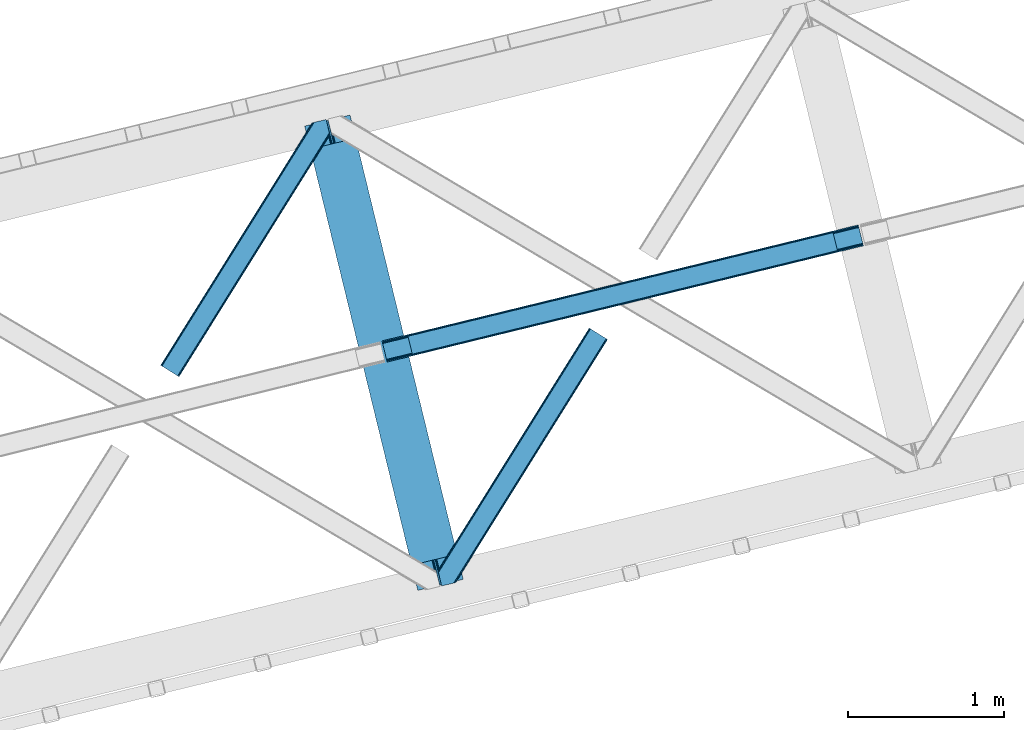
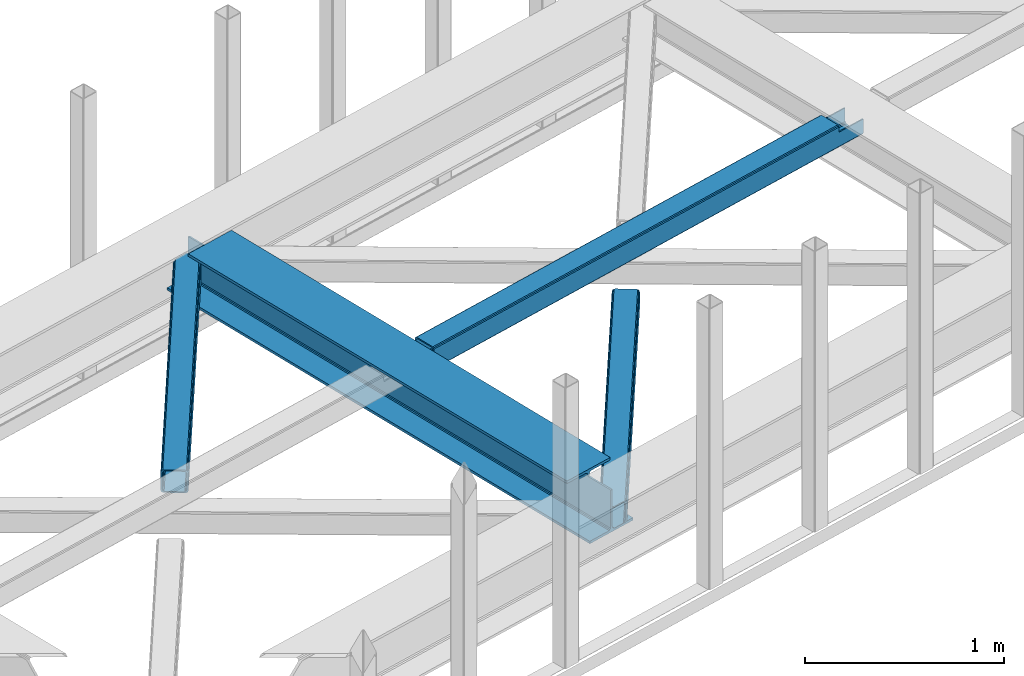
# One storey, part 40 of 66: 2 beams, 2 members.
"""IFC4 building model written with IfcOpenShell, lengths in millimetres."""

from ifc_helpers import new_model, entity, si_unit, converted_unit, derived_unit, direction, frame, origin, place, context, subcontext, project, spatial, triangles, polygons, material, type_object, element, save


model = new_model("IFC4")

# Units and contexts
model_context = context("Model", 3, precision=0.01, world=origin(), true_north=direction((6.12303176911189e-17, 1.0)))
plan_context = context("Plan", 3, precision=0.01, world=origin(), true_north=direction((6.12303176911189e-17, 1.0)))
body_context = subcontext(model_context, "Body", "Model", "MODEL_VIEW")
ifc_project = project(units=[si_unit("LENGTHUNIT", "METRE", prefix="MILLI"), si_unit("AREAUNIT", "SQUARE_METRE"), si_unit("VOLUMEUNIT", "CUBIC_METRE"), converted_unit("PLANEANGLEUNIT", "DEGREE", entity("IfcRatioMeasure", 0.0174532925199433), si_unit("PLANEANGLEUNIT", "RADIAN"), dimensions=[0, 0, 0, 0, 0, 0, 0]), si_unit("MASSUNIT", "GRAM", prefix="KILO"), derived_unit("MASSDENSITYUNIT", [(si_unit("MASSUNIT", "GRAM", prefix="KILO"), 1), (si_unit("LENGTHUNIT", "METRE"), -3)]), derived_unit("MOMENTOFINERTIAUNIT", [(si_unit("LENGTHUNIT", "METRE"), 4)]), si_unit("TIMEUNIT", "SECOND"), si_unit("FREQUENCYUNIT", "HERTZ"), si_unit("THERMODYNAMICTEMPERATUREUNIT", "DEGREE_CELSIUS"), derived_unit("THERMALTRANSMITTANCEUNIT", [(si_unit("MASSUNIT", "GRAM", prefix="KILO"), 1), (si_unit("THERMODYNAMICTEMPERATUREUNIT", "KELVIN"), -1), (si_unit("TIMEUNIT", "SECOND"), -3)]), derived_unit("VOLUMETRICFLOWRATEUNIT", [(si_unit("LENGTHUNIT", "METRE"), 3), (si_unit("TIMEUNIT", "SECOND"), -1)]), derived_unit("MASSFLOWRATEUNIT", [(si_unit("MASSUNIT", "GRAM", prefix="KILO"), 1), (si_unit("TIMEUNIT", "SECOND"), -1)]), derived_unit("ROTATIONALFREQUENCYUNIT", [(si_unit("TIMEUNIT", "SECOND"), -1)]), si_unit("ELECTRICCURRENTUNIT", "AMPERE"), si_unit("ELECTRICVOLTAGEUNIT", "VOLT"), si_unit("POWERUNIT", "WATT"), si_unit("FORCEUNIT", "NEWTON", prefix="KILO"), si_unit("ILLUMINANCEUNIT", "LUX"), si_unit("LUMINOUSFLUXUNIT", "LUMEN"), si_unit("LUMINOUSINTENSITYUNIT", "CANDELA"), derived_unit("USERDEFINED", [(si_unit("MASSUNIT", "GRAM", prefix="KILO"), -1), (si_unit("LENGTHUNIT", "METRE"), -2), (si_unit("TIMEUNIT", "SECOND"), 3), (si_unit("LUMINOUSFLUXUNIT", "LUMEN"), 1)]), derived_unit("LINEARVELOCITYUNIT", [(si_unit("LENGTHUNIT", "METRE"), 1), (si_unit("TIMEUNIT", "SECOND"), -1)]), si_unit("PRESSUREUNIT", "PASCAL"), derived_unit("USERDEFINED", [(si_unit("LENGTHUNIT", "METRE"), -2), (si_unit("MASSUNIT", "GRAM", prefix="KILO"), 1), (si_unit("TIMEUNIT", "SECOND"), -2)]), derived_unit("LINEARFORCEUNIT", [(si_unit("MASSUNIT", "GRAM", prefix="KILO"), 1), (si_unit("LENGTHUNIT", "METRE"), 1), (si_unit("TIMEUNIT", "SECOND"), -2), (si_unit("LENGTHUNIT", "METRE"), -1)]), derived_unit("PLANARFORCEUNIT", [(si_unit("MASSUNIT", "GRAM", prefix="KILO"), 1), (si_unit("LENGTHUNIT", "METRE"), 1), (si_unit("TIMEUNIT", "SECOND"), -2), (si_unit("LENGTHUNIT", "METRE"), -2)])], contexts=[model_context, plan_context])

# Site, building, storey
site_placement = place(None, origin())
site = spatial("IfcSite", under=ifc_project, at=site_placement, CompositionType="ELEMENT")
building_placement = place(site_placement, origin())
building = spatial("IfcBuilding", under=site, at=building_placement, CompositionType="ELEMENT")
storey_placement = place(building_placement, frame((0.0, 0.0, 19800.0)))
storey = spatial("IfcBuildingStorey", under=building, at=storey_placement, Name="06", CompositionType="ELEMENT", Elevation=19800.0)

# Beams
ifc_material = material(Name="Metal painted (White)")
beam_type = type_object("IfcBeamType", PredefinedType="BEAM")
beam_1_placement = place(storey_placement, frame((-27234.93, 11156.13, 3807.02)))
element("IfcBeam", 1, at=beam_1_placement, inside=storey, type_object=beam_type, material=ifc_material, ObjectType="Steel Beam", PredefinedType="BEAM", context=body_context, shape_type="Tessellation", body=[
    polygons([(1018.16648378329, 71.0478278970978, 15.5000000000008), (1018.16648378329, 71.0478278970978, 0.0), (291.465617442442, 3052.25531830421, 0.0), (291.465617442438, 3052.25531830421, 15.5000000000008), (894.779372399329, 40.970914087327, 15.5000000000008), (168.078506058478, 3022.17840449444, 15.5000000000008), (888.087028625371, 39.3395844888221, 16.8701684147984), (161.38616228452, 3020.54707489593, 16.8701684147984), (882.413533524751, 37.9566100336497, 20.7720779386434), (155.7126671839, 3019.16410044076, 20.7720779386434), (878.622625296176, 37.0325360459162, 26.6116982174294), (151.921758955325, 3018.24002645303, 26.6116982174294), (877.291435352783, 36.7080444135007, 33.500000000001), (150.590569011928, 3017.91553482061, 33.500000000001), (140.875048430518, 3015.54727389071, 33.500000000001), (140.875048430518, 3015.54727389071, 259.000000000002), (150.590569011928, 3017.91553482061, 259.000000000002), (0.0, 2981.20749040711, 0.0), (0.0, 2981.20749040711, 15.4999999999965), (123.387111383968, 3011.28440421688, 15.5000000000008), (130.079455157922, 3012.91573381539, 16.8701684147984), (135.752950258546, 3014.29870827056, 20.7720779386391), (139.543858487122, 3015.2227822583, 26.6116982174294), (877.291435352783, 36.7080444135007, 259.000000000002), (867.575914771365, 34.3397834835992, 259.000000000002), (867.575914771365, 34.3397834835992, 33.500000000001), (866.244724827968, 34.0152918511816, 26.6116982174294), (862.453816599393, 33.0912178634481, 20.7720779386391), (856.780321498769, 31.7082434082757, 16.8701684147984), (850.087977724815, 30.076913809773, 15.5000000000008), (726.700866340847, 0.0, 15.4999999999965), (726.700866340847, -2.16573425859679e-12, 0.0), (838.124523615916, 197.385937999179, 259.069791973884), (186.469722099971, 2870.72539801218, 259.000000000002), (186.693115201825, 2869.80895360721, 259.617303331124), (186.70550404545, 2869.75812937344, 266.500003008253), (837.979344808147, 197.981416001704, 266.500002998871), (837.979694928895, 197.979979696968, 260.000004007589), (828.499586345876, 194.645865944429, 259.006343171919), (828.276216326107, 195.562317481909, 259.617303331124), (828.263827482481, 195.613141715683, 266.500003008253), (176.989986719784, 2867.38985508742, 266.500002998871), (176.989636599036, 2867.39129139215, 260.000004007589), (176.844830940692, 2867.98534020594, 259.07612046749), (176.754201518548, 2868.35713708228, 259.000000000002), (839.310832678066, 198.304685446386, 273.388305639783), (843.101109266766, 199.231350618303, 279.227924098781), (848.7741802143, 200.616065081979, 283.129832400619), (855.466371895434, 202.24801861279, 284.500000377228), (978.853400583269, 232.3252716679, 284.500000138971), (978.851730776613, 232.332121736633, 299.999995328161), (687.386308679343, 161.283492472591, 299.999995890962), (687.387978486003, 161.276642403861, 284.500000701776), (810.775007173847, 191.353895458972, 284.500000463519), (817.467494069986, 192.984637925548, 283.129832461069), (823.141405718746, 194.365903570074, 279.227924137322), (826.932940505738, 195.28740721937, 273.388305663684), (175.658498849852, 2867.06658564273, 273.388305639783), (171.868222261156, 2866.13992047082, 279.227924098781), (166.195151313627, 2864.75520600714, 283.129832400619), (159.502959632497, 2863.12325247633, 284.500000377228), (36.115930944649, 2833.04599942122, 284.500000138971), (36.1176007513094, 2833.03914935249, 299.999995328161), (327.583022848575, 2904.08777861653, 299.999995890962), (327.581353041919, 2904.09462868526, 284.500000701776), (204.194324354084, 2874.01737563015, 284.500000463519), (197.501837457941, 2872.38663316357, 283.129832461069), (191.827925809181, 2871.00536751904, 279.227924137322), (188.036391022185, 2870.08386386975, 273.388305663684)], [[[1, 2, 3, 4]], [[5, 1, 4, 6]], [[7, 5, 6, 8]], [[9, 7, 8, 10]], [[11, 9, 10, 12]], [[13, 11, 12, 14]], [[15, 16, 17, 14, 12, 10, 8, 6, 4, 3, 18, 19, 20, 21, 22, 23]], [[13, 24, 25, 26, 27, 28, 29, 30, 31, 32, 2, 1, 5, 7, 9, 11]], [[2, 32, 18, 3]], [[32, 31, 19, 18]], [[31, 30, 20, 19]], [[27, 26, 15, 23]], [[28, 27, 23, 22]], [[29, 28, 22, 21]], [[30, 29, 21, 20]], [[33, 24, 13, 14, 17, 34, 35, 36, 37, 38]], [[25, 39, 40, 41, 42, 43, 44, 16, 15, 26]], [[39, 25, 24, 33]], [[45, 34, 17, 16]], [[41, 40, 38, 37, 46, 47, 48, 49, 50, 51, 52, 53, 54, 55, 56, 57]], [[42, 58, 59, 60, 61, 62, 63, 64, 65, 66, 67, 68, 69, 36, 35, 43]], [[46, 37, 36, 69]], [[47, 46, 69, 68]], [[48, 47, 68, 67]], [[49, 48, 67, 66]], [[50, 49, 66, 65]], [[51, 50, 65, 64]], [[52, 51, 64, 63]], [[53, 52, 63, 62]], [[54, 53, 62, 61]], [[55, 54, 61, 60]], [[56, 55, 60, 59]], [[57, 56, 59, 58]], [[41, 57, 58, 42]]], closed=False),
])
beam_2_placement = place(storey_placement, frame((-26738.19, 12622.23, 3967.02)))
element("IfcBeam", 2, at=beam_2_placement, inside=storey, type_object=beam_type, material=ifc_material, ObjectType="Steel Beam", PredefinedType="BEAM", context=body_context, shape_type="Tessellation", body=[
    polygons([(31.1823923917614, 8.09507685196108, 17.8030399336114), (31.4978703677143, 6.80086440699217, 24.4999999999988), (3089.94374939705, 752.329405140566, 24.4999999999988), (3089.62827142109, 753.623617585535, 17.8030399336114), (30.2839871259035, 11.7806820741864, 12.1256313292298), (3088.72986615524, 757.309222807764, 12.1256313292298), (28.9394286278148, 17.2965800886753, 8.33210818105214), (3087.38530765716, 762.825120822251, 8.33210818105214), (27.3534137403861, 23.8030254244661, 7.00000000000274), (3085.79929276972, 769.331566158042, 7.00000000000274), (4.21622439082827, 118.720708051131, 8.33210818105214), (5.80223927826556, 112.214262715341, 7.00000000000274), (3064.2481183076, 857.742803448919, 7.00000000000274), (3062.66210342017, 864.249248784707, 8.33210818105214), (2.87166589274391, 124.236606065618, 12.1256313292342), (3061.31754492208, 869.765146799196, 12.1256313292342), (1.9732606268946, 127.922211287846, 17.8030399336114), (3060.41913965623, 873.450752021424, 17.8030399336114), (1.65778265093302, 129.216423732817, 24.4999999999988), (3060.10366168026, 874.744964466395, 24.4999999999988), (33.1556530186517, 0.0, 17.5000000000004), (33.1556530186517, 0.0, 99.499999999999), (31.497870367723, 6.80086440699001, 99.499999999999), (1.65778265093735, 129.216423732817, 99.499999999999), (4.33146851719357e-12, 136.017288139807, 99.499999999999), (4.33146851719357e-12, 136.017288139807, 17.5000000000004), (0.315477975965916, 134.723075694838, 10.803039933613), (1.21388324181955, 131.037470472612, 5.12563132923143), (2.55844173990391, 125.521572458124, 1.33210818105373), (4.14445662733254, 119.015127122331, 0.0), (29.0111963913192, 17.0021610174761, 0.0), (30.5972112787564, 10.4957156816853, 1.33210818105373), (31.9417697768408, 4.97981766719418, 5.12563132923576), (32.8401750426901, 1.29421244496891, 10.803039933613), (3058.44587902933, 881.54582887338, 17.5000000000004), (3058.44587902933, 881.54582887338, 99.499999999999), (3060.10366168026, 874.74496446639, 99.499999999999), (3089.94374939704, 752.329405140566, 99.499999999999), (3091.60153204797, 745.528540733574, 99.499999999999), (3091.60153204797, 745.528540733574, 17.5000000000004), (3091.28605407202, 746.822753178543, 10.803039933613), (3090.38764880616, 750.508358400766, 5.12563132923576), (3089.04309030808, 756.024256415259, 1.33210818105373), (3087.45707542064, 762.53070175105, 0.0), (3062.59033565666, 864.543667855904, 0.0), (3061.00432076922, 871.050113191697, 1.33210818105373), (3059.65976227114, 876.566011206186, 5.12563132923143), (3058.76135700529, 880.251616428411, 10.803039933613), (2925.75994180941, 712.307865540878, 115.5000123926), (2925.81630989428, 712.321604759496, 100.117303289864), (2926.72300362928, 712.542621518191, 99.499999999999), (194.718606580805, 46.5876811586757, 99.5063429816656), (195.631369831917, 46.8101414945052, 100.117301735448), (195.690168193631, 46.824474122359, 115.5), (2928.38078628021, 705.741757111199, 99.499999999999), (2927.47422618797, 705.520772937691, 100.117303484932), (2927.41464342029, 705.506249905349, 122.500007895425), (197.345360928052, 40.0229783796067, 122.500002534479), (197.338587096745, 40.02132714415, 100.500009163303), (196.74820519572, 39.8773799905087, 99.5697919021647), (2896.88292546718, 834.958147714707, 99.5063429816656), (2895.97381660772, 834.736577551995, 100.117299778624), (2895.91744852285, 834.722838333377, 115.50000888136), (165.850080476841, 169.240033448183, 115.5), (165.840462203343, 169.237688832044, 100.50000941238), (165.250325295037, 169.093836777333, 99.5761204674868), (2894.85332685227, 841.668448882878, 99.5697919021647), (163.220745767773, 175.804071762186, 99.499999999999), (164.133244938519, 176.026503182399, 100.117301984524), (164.189439987632, 176.040201208968, 122.500002796667), (2894.25631754634, 841.522886341455, 122.500003994045), (2894.26642083517, 841.525349756027, 100.500018741102), (2894.56843170073, 840.227853719294, 129.196959150505), (2895.46176722632, 836.541012377604, 134.874360354937), (2896.80305823039, 831.024317672795, 138.667878733795), (2898.38810531639, 824.51763636472, 139.999985502214), (2923.25885436332, 722.505647815409, 139.999991354279), (2924.84634848091, 715.999563150004, 138.667885332354), (2926.19460804134, 710.484567539777, 134.874367586349), (2927.09837274855, 706.800269072823, 129.196966804773), (2925.44675217771, 713.602635936895, 122.196975799125), (2924.54298747049, 717.286934403852, 127.874376580702), (2923.19472791006, 722.801930014079, 131.667894326702), (2921.60723379248, 729.308014679482, 133.000000348631), (2900.05258461847, 817.71840475555, 132.999995276841), (2898.46753753246, 824.225086063627, 131.667888508414), (2897.1262465284, 829.74178076843, 127.874370129564), (2896.23291100281, 833.428622110126, 122.196968925133), (164.878528418706, 169.003207355194, 99.499999999999), (193.131726453732, 57.3201898040399, 131.667891818946), (191.545711566294, 63.8266351398329, 133.0), (194.476284951812, 51.8042917895531, 127.874368670764), (195.37469021767, 48.1186865673279, 122.196960066391), (169.994537104174, 152.237872430709, 133.0), (166.165558452803, 167.945821003215, 122.196960066391), (167.063963718652, 164.260215780989, 127.874368670764), (168.408522216736, 158.744317766502, 131.667891818946), (197.031411944078, 41.3175635421159, 129.196961104604), (196.136488323061, 45.0040174739024, 134.874366301861), (194.794244157319, 50.5204796458751, 138.667887185257), (193.209023953586, 57.0271186992015, 139.999994588639), (168.341882306941, 159.039986838392, 139.999994981919), (166.755021471189, 165.546225960036, 138.667887628704), (165.408105180735, 171.06154922293, 134.874366787843), (164.506189230965, 174.746298656828, 129.196961619)], [[[1, 2, 3, 4]], [[5, 1, 4, 6]], [[7, 5, 6, 8]], [[9, 7, 8, 10]], [[11, 12, 13, 14]], [[15, 11, 14, 16]], [[17, 15, 16, 18]], [[19, 17, 18, 20]], [[12, 9, 10, 13]], [[21, 22, 23, 2, 1, 5, 7, 9, 12, 11, 15, 17, 19, 24, 25, 26, 27, 28, 29, 30, 31, 32, 33, 34]], [[35, 36, 37, 20, 18, 16, 14, 13, 10, 8, 6, 4, 3, 38, 39, 40, 41, 42, 43, 44, 45, 46, 47, 48]], [[49, 50, 51, 38, 3, 2, 23, 52, 53, 54]], [[55, 39, 38, 51]], [[39, 55, 56, 57, 58, 59, 60, 22, 21, 40]], [[32, 31, 44, 43]], [[33, 32, 43, 42]], [[34, 33, 42, 41]], [[21, 34, 41, 40]], [[31, 30, 45, 44]], [[27, 26, 35, 48]], [[28, 27, 48, 47]], [[29, 28, 47, 46]], [[30, 29, 46, 45]], [[20, 37, 61, 62, 63, 64, 65, 66, 24, 19]], [[67, 36, 35, 26, 25, 68, 69, 70, 71, 72]], [[36, 67, 61, 37]], [[72, 71, 73, 74, 75, 76, 77, 78, 79, 80, 57, 56, 50, 49, 81, 82, 83, 84, 85, 86, 87, 88, 63, 62]], [[60, 52, 23, 22]], [[25, 24, 89, 68]], [[90, 91, 84, 83]], [[92, 90, 83, 82]], [[93, 92, 82, 81]], [[54, 93, 81, 49]], [[94, 85, 84, 91]], [[95, 64, 63, 88]], [[96, 95, 88, 87]], [[97, 96, 87, 86]], [[94, 97, 86, 85]], [[65, 64, 95, 96, 97, 94, 91, 90, 92, 93, 54, 53, 59, 58, 98, 99, 100, 101, 102, 103, 104, 105, 70, 69]], [[98, 58, 57, 80]], [[99, 98, 80, 79]], [[100, 99, 79, 78]], [[101, 100, 78, 77]], [[77, 76, 102, 101]], [[103, 102, 76, 75]], [[104, 103, 75, 74]], [[105, 104, 74, 73]], [[70, 105, 73, 71]]], closed=False),
])

# Members
member_type_1 = type_object("IfcMemberType", PredefinedType="BRACE")
member_1_placement = place(storey_placement, frame((-28160.16, 12527.49, 3823.0)))
element("IfcMember", 3, at=member_1_placement, inside=storey, type_object=member_type_1, ObjectType="Steel Horizontal Brace", PredefinedType="BRACE", context=body_context, shape_type="Tessellation", body=[
    triangles([(933.019793701173, 1535.69230957031, 0.0), (967.780462646486, 1393.09171142578, 0.0), (14.8479309082031, 64.8704589843746, 0.0), (103.9169128418, 9.2680389404286, 0.0), (928.803771972656, 1552.99125366211, 5.49966430664063), (928.943298339844, 1552.41687011719, 5.208984375), (930.803649902344, 1544.78710327148, 1.33247680664135), (971.998809814453, 1375.79276733398, 5.49966430664063), (971.856958007815, 1376.36715087891, 5.208984375), (969.998931884766, 1383.99691772461, 1.33247680664135), (972.210424804689, 1375.53813171387, 5.8531311035149), (972.424365234376, 1375.28349609375, 6.20659790039281), (928.915393066407, 1553.57028808594, 5.74383544921875), (972.726672363282, 1375.53813171387, 6.35310058593677), (929.029339599612, 1554.1772277832, 5.9996337890625), (973.026654052737, 1375.79276733398, 6.49960327148438), (929.145611572269, 1554.78416748047, 6.25543212890625), (929.254907226565, 1555.36203918457, 6.49960327148438), (4.34857177734375, 71.4223846435543, 5.12526855468968), (1.13248901367479, 73.4315643310547, 10.8039916992202), (973.361517333986, 1630.84347839355, 10.8039916992202), (976.917114257813, 1631.70970458984, 6.49960327148438), (9.16455688476708, 68.415591430663, 1.33247680664135), (971.508142089846, 1630.39118041992, 17.5012573242202), (0.0, 74.1373352050778, 17.5012573242202), (1081.10145263672, 1548.91708374023, 6.49960327148438), (1056.20762329102, 1651.03759460449, 6.49960327148438), (971.508142089846, 1630.39118041992, 122.499499511719), (0.0, 74.1373352050778, 122.499499511719), (973.361517333986, 1630.84347839355, 129.196765136719), (1.13248901367479, 73.4315643310547, 129.196765136719), (978.633288574219, 1632.12828369141, 134.87548828125), (4.34857177734375, 71.4223846435543, 134.87548828125), (986.530480957033, 1634.05374755859, 138.668280029298), (9.16455688476708, 68.415591430663, 138.668280029298), (995.841540527344, 1636.32221374512, 140.00075683594), (14.8479309082031, 64.8704589843746, 140.00075683594), (118.760192871094, 0.0, 17.5012573242202), (117.632354736328, 0.705770874023074, 10.8039916992202), (1085.14306640625, 1551.25066223144, 10.9783996582046), (1087.41734619141, 1552.56453552246, 13.4991760253906), (109.597961425781, 5.7205810546875, 1.33247680664135), (114.413946533205, 2.71495056152344, 5.12526855468968), (1087.57082519531, 1551.93550415039, 17.5012573242202), (1081.77815551758, 1575.70265808105, 140.00075683594), (1063.00953369141, 1652.69563293457, 140.00075683594), (103.9169128418, 9.2680389404286, 140.00075683594), (1083.99429931641, 1566.60670166016, 138.668280029298), (109.597961425781, 5.7205810546875, 138.668280029298), (1085.87325439453, 1558.89670715332, 134.87548828125), (114.413946533205, 2.71495056152344, 134.87548828125), (1087.12899169922, 1553.74469604492, 129.196765136719), (117.632354736328, 0.705770874023074, 129.196765136719), (1087.57082519531, 1551.93550415039, 122.499499511719), (118.760192871094, 0.0, 122.499499511719), (1082.53857421875, 1566.77413330078, 12.1248413085959), (1083.96639404297, 1566.72413635254, 13.4991760253906), (1077.8528137207, 1569.98556518555, 8.3320495605476), (1074.6483581543, 1577.50138549805, 6.99957275390625), (1056.69364013672, 1651.1561920166, 6.99957275390625), (1005.57350463867, 1638.69532470703, 6.99957275390625), (20.784777832032, 61.1625457763676, 6.99957275390625), (97.9777404785164, 12.9736267089847, 6.99957275390625), (108.474774169925, 6.42170104980505, 12.1248413085959), (111.693182373048, 4.41252136230469, 17.8035644531265), (1084.81285400391, 1563.2510925293, 17.8035644531265), (103.661114501956, 9.42849426269458, 8.3320495605476), (1085.25236206055, 1561.44190063477, 24.5008300781265), (112.823345947269, 3.70791320800708, 24.5008300781265), (983.093481445314, 1633.21542663574, 17.8035644531265), (981.240106201174, 1632.76429138184, 24.5008300781265), (7.0693359375, 69.7248138427731, 17.8035644531265), (5.94149780273438, 70.4305847167961, 24.5008300781265), (988.369903564453, 1634.50139465332, 12.1248413085959), (10.2877441406272, 67.7156341552727, 12.1248413085959), (996.262445068362, 1636.42569580078, 8.3320495605476), (15.1037292480469, 64.7100036621086, 8.3320495605476), (981.240106201174, 1632.76429138184, 115.499926757813), (5.94149780273438, 70.4305847167961, 115.499926757813), (996.262445068362, 1636.42569580078, 131.668707275392), (1005.57350463867, 1638.69532470703, 133.001184082033), (1063.00953369141, 1652.69563293457, 133.001184082033), (988.369903564453, 1634.50139465332, 127.873590087893), (983.093481445314, 1633.21542663574, 122.197192382813), (20.784777832032, 61.1625457763676, 133.001184082033), (15.1037292480469, 64.7100036621086, 131.668707275392), (10.2877441406272, 67.7156341552727, 127.873590087893), (7.0693359375, 69.7248138427731, 122.197192382813), (108.474774169925, 6.42170104980505, 127.873590087893), (111.693182373048, 4.41252136230469, 122.197192382813), (112.823345947269, 3.70791320800708, 115.499926757813), (97.9777404785164, 12.9736267089847, 133.001184082033), (103.661114501956, 9.42849426269458, 131.668707275392), (1085.25236206055, 1561.44190063477, 115.499926757813), (1084.81285400391, 1563.2510925293, 122.197192382813), (1083.55711669922, 1568.40310363769, 127.873590087893), (1081.67583618164, 1576.11309814453, 131.668707275392), (1079.45969238281, 1585.20905456543, 133.001184082033)], [[1, 2, 3], [4, 3, 2], [1, 5, 2], [6, 5, 1], [1, 7, 6], [2, 5, 8], [8, 9, 2], [10, 2, 9], [11, 8, 5], [12, 11, 13], [14, 12, 15], [16, 14, 17], [17, 18, 16], [15, 17, 14], [13, 15, 12], [5, 13, 11], [17, 19, 18], [19, 17, 15], [13, 19, 15], [19, 13, 5], [5, 6, 19], [20, 21, 18], [18, 19, 20], [21, 22, 18], [19, 6, 7], [7, 1, 23], [3, 23, 1], [7, 23, 19], [24, 21, 20], [20, 25, 24], [18, 26, 16], [26, 18, 22], [27, 26, 22], [28, 24, 25], [25, 29, 28], [30, 28, 31], [29, 31, 28], [32, 30, 33], [31, 33, 30], [34, 32, 35], [33, 35, 32], [36, 34, 37], [35, 37, 34], [38, 39, 40], [40, 41, 38], [42, 10, 9], [39, 12, 16], [16, 40, 39], [16, 26, 40], [9, 39, 43], [9, 12, 39], [9, 43, 42], [2, 10, 4], [42, 4, 10], [41, 44, 38], [45, 36, 37], [36, 45, 46], [37, 47, 45], [48, 45, 47], [47, 49, 48], [50, 48, 49], [49, 51, 50], [52, 50, 51], [51, 53, 52], [54, 52, 53], [53, 55, 54], [44, 54, 55], [55, 38, 44], [56, 40, 26], [41, 40, 56], [56, 57, 41], [58, 26, 59], [26, 58, 56], [60, 59, 26], [59, 61, 62], [61, 59, 60], [62, 63, 59], [64, 65, 66], [66, 57, 64], [58, 59, 63], [63, 67, 58], [56, 58, 67], [67, 64, 56], [57, 56, 64], [68, 66, 65], [65, 69, 68], [70, 71, 72], [73, 72, 71], [74, 70, 75], [72, 75, 70], [76, 74, 77], [75, 77, 74], [61, 76, 62], [77, 62, 76], [71, 78, 73], [79, 73, 78], [34, 36, 80], [46, 81, 36], [81, 46, 82], [81, 80, 36], [83, 34, 80], [83, 32, 34], [32, 84, 30], [84, 32, 83], [28, 84, 78], [84, 28, 30], [61, 22, 76], [70, 74, 22], [74, 76, 22], [61, 60, 22], [71, 70, 24], [21, 24, 70], [28, 71, 24], [71, 28, 78], [70, 22, 21], [80, 81, 85], [85, 86, 80], [83, 80, 86], [86, 87, 83], [84, 83, 87], [87, 88, 84], [78, 84, 88], [88, 79, 78], [53, 89, 90], [91, 38, 55], [53, 90, 55], [53, 51, 89], [90, 91, 55], [89, 51, 49], [92, 47, 37], [47, 93, 49], [93, 47, 92], [93, 89, 49], [39, 64, 43], [69, 38, 91], [38, 65, 39], [65, 38, 69], [39, 65, 64], [4, 63, 3], [42, 43, 64], [64, 67, 42], [67, 63, 4], [4, 42, 67], [87, 35, 33], [37, 85, 92], [37, 86, 85], [86, 37, 35], [87, 86, 35], [79, 29, 25], [31, 88, 87], [33, 31, 87], [88, 31, 29], [79, 88, 29], [23, 75, 19], [3, 63, 62], [62, 77, 3], [77, 75, 23], [23, 3, 77], [20, 19, 75], [25, 73, 79], [72, 25, 20], [25, 72, 73], [72, 20, 75], [66, 41, 57], [54, 44, 68], [44, 66, 68], [68, 94, 54], [44, 41, 66], [95, 54, 94], [52, 54, 95], [50, 95, 96], [95, 50, 52], [96, 48, 50], [97, 48, 96], [97, 98, 45], [97, 45, 48], [98, 46, 45], [98, 82, 46], [81, 98, 85], [81, 82, 98], [92, 85, 98], [95, 94, 90], [91, 90, 94], [96, 95, 89], [90, 89, 95], [97, 96, 93], [89, 93, 96], [98, 97, 92], [93, 92, 97], [94, 68, 91], [69, 91, 68]]),
])
member_type_2 = type_object("IfcMemberType", PredefinedType="BRACE")
member_2_placement = place(storey_placement, frame((-26379.09, 11184.33, 3823.0)))
element("IfcMember", 4, at=member_2_placement, inside=storey, type_object=member_type_2, ObjectType="Steel Horizontal Brace", PredefinedType="BRACE", context=body_context, shape_type="Tessellation", body=[
    triangles([(986.153759765624, 1647.42967529297, 0.0), (1075.22274169922, 1591.82725524902, 0.0), (119.788037109374, 259.603921508789, 0.0), (154.548706054688, 117.003323364259, 0.0), (115.902227783201, 275.544808959961, 4.52065429687718), (117.571893310545, 268.698715209961, 1.33247680664135), (158.434515380857, 101.062435913087, 4.52065429687718), (156.764849853513, 107.908529663086, 1.33247680664135), (114.825549316403, 275.742471313477, 5.52059326172093), (115.130181884764, 275.923855590821, 5.35316162109302), (158.132208251951, 99.1218566894531, 5.27642211914281), (115.439465332031, 276.107565307617, 5.18107910156323), (158.232202148436, 99.7776306152355, 5.02062377929906), (158.188018798828, 99.4822998046875, 5.13457031250073), (115.541784667967, 276.1680267334, 5.12526855468968), (115.683636474609, 275.921530151367, 4.88574829101708), (158.336846923827, 100.433404541016, 4.76482543945531), (158.032214355466, 98.4928253173839, 5.52059326172093), (1085.71977539062, 1585.27416687012, 5.12526855468968), (1080.90146484375, 1588.28096008301, 1.33247680664135), (1088.93818359375, 1583.26498718262, 10.8039916992202), (114.21163330078, 21.8533172607422, 10.8039916992202), (109.467736816405, 20.6964111328125, 5.52059326172093), (1090.06602172851, 1582.56037902832, 17.5012573242202), (116.062683105469, 22.3044525146488, 17.5012573242202), (6.75307617187354, 102.619317626953, 5.52059326172093), (31.3632019042961, 1.65803833007885, 5.52059326172093), (1090.06602172851, 1582.56037902832, 122.499499511719), (116.062683105469, 22.3044525146488, 122.499499511719), (1088.93818359375, 1583.26498718262, 129.196765136719), (114.21163330078, 21.8533172607422, 129.196765136719), (1085.71977539062, 1585.27416687012, 134.87548828125), (108.935211181641, 20.5673492431652, 134.87548828125), (1080.90146484375, 1588.28096008301, 138.668280029298), (101.042669677732, 18.6430480957042, 138.668280029298), (1075.22274169922, 1591.82725524902, 140.00075683594), (91.7292846679666, 16.3722564697273, 140.00075683594), (980.472711181639, 1650.97597045899, 1.33247680664135), (975.656726074216, 1653.98276367187, 5.12526855468968), (1.69059448242115, 100.411312866212, 10.9621215820334), (972.438317871092, 1655.99078063965, 10.8039916992202), (971.308154296872, 1656.69655151367, 17.5012573242202), (0.239520263668965, 99.7776306152355, 12.5201660156272), (0.0, 100.760128784181, 17.5012573242202), (5.79266967773219, 76.9941375732433, 140.00075683594), (986.153759765624, 1647.42967529297, 140.00075683594), (24.5612915039055, 0.0, 140.00075683594), (971.308154296872, 1656.69655151367, 122.499499511719), (0.0, 100.760128784181, 122.499499511719), (980.472711181639, 1650.97597045899, 138.668280029298), (3.57652587890334, 86.0889312744148, 138.668280029298), (975.656726074216, 1653.98276367187, 134.87548828125), (1.69524536132667, 93.7989257812496, 134.87548828125), (972.438317871092, 1655.99078063965, 129.196765136719), (0.43950805663917, 98.9509368896488, 129.196765136719), (29.9237548828096, 1.30689697265734, 6.99957275390625), (12.1969299316406, 74.0326904296871, 6.99957275390625), (8.99247436523365, 81.5485107421882, 8.3320495605476), (3.88580932616969, 84.8122650146488, 12.5201660156272), (1069.28589477539, 1595.53400573731, 6.99957275390625), (81.9949951171875, 14.0003082275398, 6.99957275390625), (992.090606689453, 1643.72292480469, 6.99957275390625), (981.593572998045, 1650.27601318359, 12.1248413085959), (978.375164794921, 1652.28403015137, 17.8035644531265), (2.75797119140407, 89.4445404052731, 17.8035644531265), (986.409558105468, 1647.2692199707, 8.3320495605476), (977.245001220701, 1652.98980102539, 24.5008300781265), (2.31613769531032, 91.2537322998051, 24.5008300781265), (977.245001220701, 1652.98980102539, 115.499926757813), (2.31613769531032, 91.2537322998051, 115.499926757813), (4.01370849609157, 84.2925292968757, 127.873590087893), (2.75797119140407, 89.4445404052731, 122.197192382813), (5.89266357421729, 76.5825347900391, 131.668707275392), (8.10880737304615, 67.4865783691403, 133.001184082033), (24.5612915039055, 0.0, 133.001184082033), (978.375164794921, 1652.28403015137, 122.197192382813), (981.593572998045, 1650.27601318359, 127.873590087893), (986.409558105468, 1647.2692199707, 131.668707275392), (992.090606689453, 1643.72292480469, 133.001184082033), (1069.28589477539, 1595.53400573731, 133.001184082033), (81.9949951171875, 14.0003082275398, 133.001184082033), (1079.78060302734, 1588.9809173584, 12.1248413085959), (1082.99901123047, 1586.97290039063, 17.8035644531265), (1084.12917480469, 1586.2671295166, 24.5008300781265), (1074.96461791992, 1591.98771057129, 8.3320495605476), (1079.78060302734, 1588.9809173584, 127.873590087893), (1084.12917480469, 1586.2671295166, 115.499926757813), (1082.99901123047, 1586.97290039063, 122.197192382813), (1074.96461791992, 1591.98771057129, 131.668707275392), (91.3083801269531, 16.2699371337894, 131.668707275392), (99.2032470703125, 18.1942382812504, 127.873590087893), (104.477343749997, 19.4802062988292, 122.197192382813), (106.330718994141, 19.9325042724613, 115.499926757813), (91.3083801269531, 16.2699371337894, 8.3320495605476), (104.477343749997, 19.4802062988292, 17.8035644531265), (99.2032470703125, 18.1942382812504, 12.1248413085959), (106.330718994141, 19.9325042724613, 24.5008300781265)], [[1, 2, 3], [4, 3, 2], [5, 3, 4], [3, 5, 6], [4, 7, 5], [7, 4, 8], [9, 10, 11], [10, 12, 13], [13, 14, 10], [12, 15, 16], [16, 17, 12], [16, 5, 7], [7, 17, 16], [17, 13, 12], [14, 11, 10], [11, 18, 9], [19, 14, 13], [13, 20, 19], [13, 17, 20], [17, 7, 20], [7, 8, 20], [21, 22, 18], [18, 19, 21], [14, 19, 11], [18, 11, 19], [22, 23, 18], [21, 24, 25], [25, 22, 21], [2, 20, 4], [8, 4, 20], [23, 26, 18], [23, 27, 26], [9, 18, 26], [24, 28, 29], [29, 25, 24], [28, 30, 29], [31, 29, 30], [30, 32, 31], [33, 31, 32], [32, 34, 33], [35, 33, 34], [34, 36, 35], [37, 35, 36], [38, 6, 5], [5, 39, 38], [5, 15, 39], [40, 41, 9], [41, 39, 15], [42, 41, 40], [40, 43, 42], [43, 44, 42], [9, 26, 40], [38, 1, 6], [3, 6, 1], [36, 45, 37], [36, 46, 45], [45, 47, 37], [48, 42, 44], [44, 49, 48], [46, 50, 51], [51, 45, 46], [50, 52, 53], [53, 51, 50], [52, 54, 55], [55, 53, 52], [54, 48, 49], [49, 55, 54], [27, 56, 57], [26, 57, 58], [57, 26, 27], [59, 40, 26], [26, 58, 59], [43, 40, 59], [60, 57, 61], [60, 62, 57], [57, 56, 61], [63, 64, 65], [65, 59, 63], [66, 63, 59], [62, 66, 58], [58, 57, 62], [59, 58, 66], [64, 67, 68], [68, 65, 64], [67, 69, 70], [70, 68, 67], [71, 53, 72], [73, 74, 45], [74, 47, 45], [74, 75, 47], [51, 73, 45], [71, 51, 53], [71, 73, 51], [49, 68, 70], [55, 72, 53], [70, 72, 49], [72, 55, 49], [44, 68, 49], [43, 59, 65], [65, 68, 44], [44, 43, 65], [69, 76, 70], [72, 70, 76], [76, 77, 72], [71, 72, 77], [77, 78, 71], [73, 71, 78], [78, 79, 73], [74, 73, 79], [80, 74, 79], [74, 80, 81], [75, 74, 81], [21, 82, 83], [84, 28, 24], [21, 83, 24], [21, 19, 82], [83, 84, 24], [82, 19, 20], [60, 2, 1], [2, 85, 20], [85, 2, 60], [85, 82, 20], [30, 86, 32], [87, 28, 84], [28, 88, 30], [88, 28, 87], [30, 88, 86], [36, 80, 46], [34, 32, 86], [86, 89, 34], [89, 80, 36], [36, 34, 89], [63, 38, 39], [1, 62, 60], [1, 66, 62], [66, 1, 38], [63, 66, 38], [67, 42, 48], [41, 64, 63], [39, 41, 63], [64, 41, 42], [67, 64, 42], [50, 77, 52], [46, 80, 79], [79, 78, 46], [78, 77, 50], [50, 46, 78], [54, 52, 77], [48, 69, 67], [76, 48, 54], [48, 76, 69], [76, 54, 77], [35, 37, 90], [47, 81, 37], [81, 47, 75], [81, 90, 37], [91, 35, 90], [91, 33, 35], [33, 92, 31], [92, 33, 91], [29, 92, 93], [92, 29, 31], [61, 23, 94], [95, 96, 23], [96, 94, 23], [61, 27, 23], [27, 61, 56], [97, 95, 25], [22, 25, 95], [29, 97, 25], [97, 29, 93], [95, 23, 22], [80, 89, 90], [90, 81, 80], [89, 86, 91], [91, 90, 89], [86, 88, 92], [92, 91, 86], [88, 87, 93], [93, 92, 88], [87, 84, 97], [97, 93, 87], [84, 83, 97], [95, 97, 83], [83, 82, 95], [96, 95, 82], [82, 85, 96], [94, 96, 85], [85, 60, 94], [61, 94, 60]]),
])

save(model, "model.ifc")
